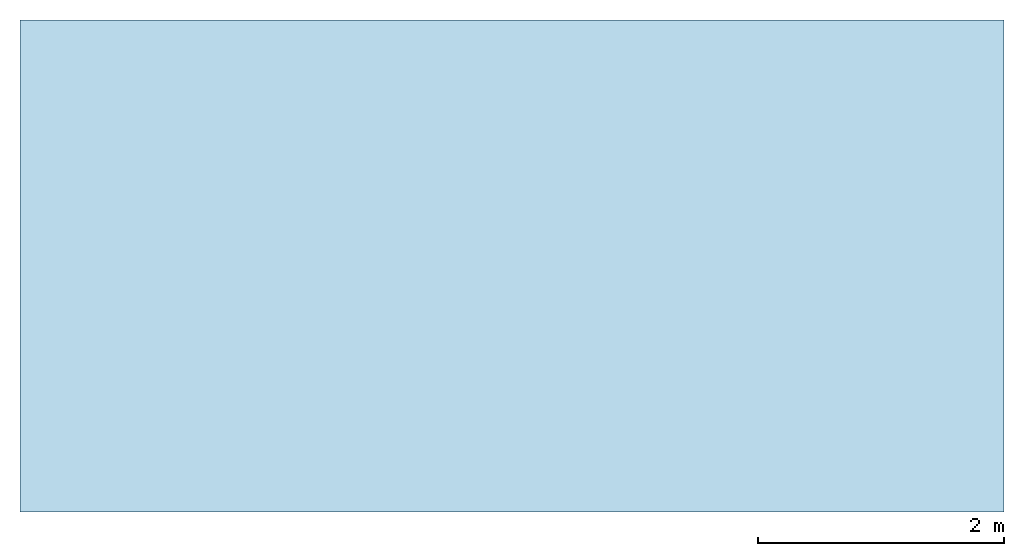
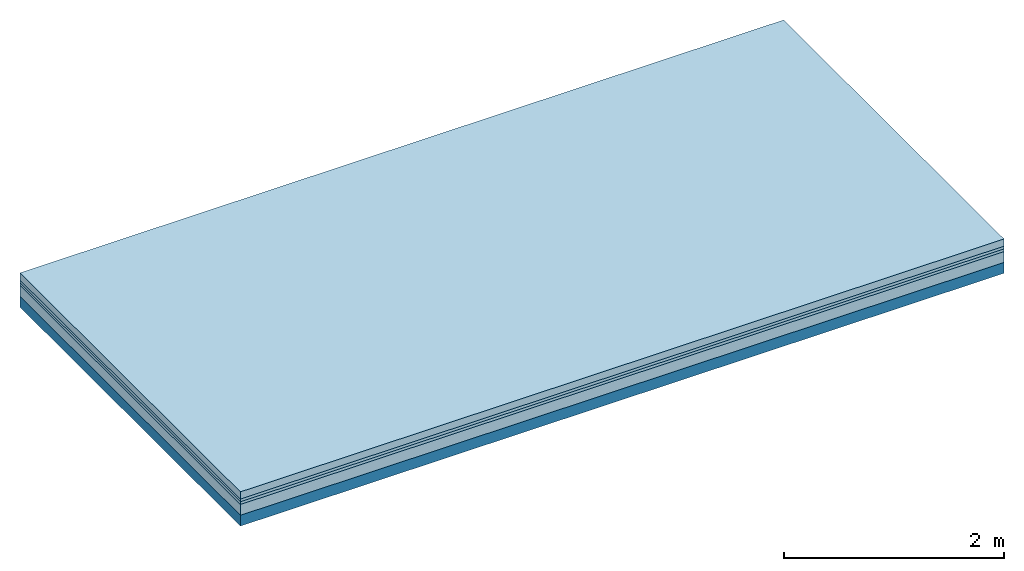
# One storey: 4 plates, 1 member, 1 element without a shape of its own.
"""IFC4 building model written with IfcOpenShell, lengths in metres."""

import ifcopenshell
import ifcopenshell.guid

model = None  # the IFC model being written
_history = None  # IfcOwnerHistory: only IFC2X3 demands one
_inside = {}  # id of a spatial element -> (the spatial element, [elements in it])
_under = {}  # id of a project, library or spatial element -> (it, [spatial elements below it])
_declared = {}  # id of a project -> (the project, [libraries it declares])
_typed = {}  # id of a type object -> (the type object, [elements of that type])
_made_of = {}  # id of a material, layer set ... -> (it, [elements and type objects made of it])


def new_model(schema):
    """Start an empty IFC model of exactly this schema.

    Asked for "IFC4X3", IfcOpenShell would pick the latest addendum, in which some entities
    have other attributes; the version numbers below select the first issue.
    IFC2X3 requires an IfcOwnerHistory on every rooted entity: one is made here for all.
    """
    global model, _history
    if schema == "IFC4X3":
        model = ifcopenshell.file(schema_version=(4, 3, 0, 0))
    else:
        model = ifcopenshell.file(schema=schema)
    _inside.clear()
    _under.clear()
    _declared.clear()
    _typed.clear()
    _made_of.clear()
    _history = None
    if model.schema == "IFC2X3":
        org = make("IfcOrganization", Name="unknown")
        user = make(
            "IfcPersonAndOrganization",
            ThePerson=make("IfcPerson", FamilyName="unknown"),
            TheOrganization=org,
        )
        app = make(
            "IfcApplication",
            ApplicationDeveloper=org,
            Version="unknown",
            ApplicationFullName="unknown",
            ApplicationIdentifier="unknown",
        )
        _history = make(
            "IfcOwnerHistory",
            OwningUser=user,
            OwningApplication=app,
            ChangeAction="ADDED",
            CreationDate=0,
        )
    return model


def make(cls, **values):
    """One entity of the class cls with the attributes given. An attribute that is None is left unset."""
    return model.create_entity(
        cls, **{name: value for name, value in values.items() if value is not None}
    )


def rooted(cls, **values):
    """An entity with a GlobalId (a new one), such as an element, a storey or a relation."""
    return make(cls, GlobalId=ifcopenshell.guid.new(), OwnerHistory=_history, **values)


def si_unit(unit_type, name, prefix=None):
    """IfcSIUnit, for example si_unit("LENGTHUNIT", "METRE", prefix="MILLI")."""
    return make("IfcSIUnit", UnitType=unit_type, Prefix=prefix, Name=name)


def derived_unit(unit_type, elements):
    """IfcDerivedUnit: a product of units, each with its exponent."""
    return make(
        "IfcDerivedUnit",
        Elements=[
            make("IfcDerivedUnitElement", Unit=unit, Exponent=power)
            for unit, power in elements
        ],
        UnitType=unit_type,
    )


def assignment(units):
    """IfcUnitAssignment: the units of a project."""
    return None if units is None else make("IfcUnitAssignment", Units=units)


def point(xyz):
    """IfcCartesianPoint."""
    return None if xyz is None else make("IfcCartesianPoint", Coordinates=xyz)


def direction(xyz):
    """IfcDirection."""
    return None if xyz is None else make("IfcDirection", DirectionRatios=xyz)


def frame(location, z_axis=None, x_axis=None):
    """IfcAxis2Placement3D, a coordinate frame: its origin and axes. An axis left out is left unset."""
    return make(
        "IfcAxis2Placement3D",
        Location=point(location),
        Axis=direction(z_axis),
        RefDirection=direction(x_axis),
    )


def frame_2d(location, x_axis=None):
    """IfcAxis2Placement2D, a coordinate frame in the plane: its origin and x axis."""
    return make(
        "IfcAxis2Placement2D", Location=point(location), RefDirection=direction(x_axis)
    )


def origin():
    """The frame at (0, 0, 0) with its axes left unset."""
    return frame((0.0, 0.0, 0.0))


def origin_with_axes():
    """The frame at (0, 0, 0) with the z axis (0, 0, 1) and the x axis (1, 0, 0) written out."""
    return frame((0.0, 0.0, 0.0), z_axis=(0.0, 0.0, 1.0), x_axis=(1.0, 0.0, 0.0))


def place(relative_to, where):
    """IfcLocalPlacement: puts the frame where relative to a parent placement (None: the world)."""
    return make(
        "IfcLocalPlacement", PlacementRelTo=relative_to, RelativePlacement=where
    )


def context(
    kind, dimensions, precision=None, world=None, true_north=None, identifier=None
):
    """IfcGeometricRepresentationContext, for example the 3D "Model" context."""
    return make(
        "IfcGeometricRepresentationContext",
        ContextIdentifier=identifier,
        ContextType=kind,
        CoordinateSpaceDimension=dimensions,
        Precision=precision,
        WorldCoordinateSystem=world,
        TrueNorth=true_north,
    )


def project(units=None, contexts=None):
    """IfcProject with its units and contexts."""
    return rooted(
        "IfcProject",
        Name="project",
        RepresentationContexts=contexts,
        UnitsInContext=assignment(units),
    )


def spatial(cls, under=None, at=None, **own):
    """A site, building, storey or space (cls), placed at a placement, below another one or the project."""
    s = rooted(cls, ObjectPlacement=at, **own)
    if under is not None:
        _under.setdefault(under.id(), (under, []))[1].append(s)
    return s


def profile(cls, at=None, kind="AREA", **sizes):
    """A parametric profile (cls). Its sizes go by their IFC names, for example OverallWidth=200.0."""
    return make(cls, ProfileType=kind, Position=at, **sizes)


def rectangle(**sizes):
    """IfcRectangleProfileDef."""
    return profile("IfcRectangleProfileDef", **sizes)


def extrude(swept, where, along, depth):
    """IfcExtrudedAreaSolid: the profile swept, set in the frame where, extruded along a direction by depth."""
    return make(
        "IfcExtrudedAreaSolid",
        SweptArea=swept,
        Position=where,
        ExtrudedDirection=direction(along),
        Depth=depth,
    )


def shape(context_of_items, identifier, shape_type, items):
    """IfcShapeRepresentation: the items that make up one representation, for example the "Body"."""
    return make(
        "IfcShapeRepresentation",
        ContextOfItems=context_of_items,
        RepresentationIdentifier=identifier,
        RepresentationType=shape_type,
        Items=items,
    )


def material(Name=None, Category=None):
    """IfcMaterial."""
    return make("IfcMaterial", Name=Name, Category=Category)


def layer(
    of_material, thickness, ventilated=None, Name=None, Category=None, Priority=None
):
    """IfcMaterialLayer: one layer of a wall or slab, of a material (None: an air gap)."""
    return make(
        "IfcMaterialLayer",
        Material=of_material,
        LayerThickness=thickness,
        IsVentilated=ventilated,
        Name=Name,
        Category=Category,
        Priority=Priority,
    )


def layer_set(layers, Name=None):
    """IfcMaterialLayerSet."""
    return make("IfcMaterialLayerSet", MaterialLayers=layers, LayerSetName=Name)


def made_of(thing, what):
    """Note that an element or type object is made of a material, layer set ...; save() writes the relation."""
    if what is not None:
        _made_of.setdefault(what.id(), (what, []))[1].append(thing)
    return thing


def type_object(cls, material=None, **own):
    """A type object (cls), such as IfcWallType, which elements share."""
    return made_of(rooted(cls, **own), material)


def element(
    cls,
    number,
    at=None,
    inside=None,
    cuts=None,
    type_object=None,
    material=None,
    context=None,
    identifier="Body",
    shape_type=None,
    held_by="IfcProductDefinitionShape",
    body=None,
    shapes=None,
    **own,
):
    """One element of the class cls, such as IfcWall. Its Tag is "e" and its number.

    at: its placement. inside: the storey or other place that contains it. cuts: it is an
    opening in that element (IfcRelVoidsElement). A single representation is given by context,
    identifier, shape_type and body (its items); several are given by shapes. held_by: the class
    of the entity that holds the representations. save() writes the other relations.
    """
    e = rooted(cls, Tag="e%d" % number, ObjectPlacement=at, **own)
    if body is not None:
        shapes = [shape(context, identifier, shape_type, body)]
    if shapes is not None:
        e.Representation = make(held_by, Representations=shapes)
    if inside is not None:
        _inside.setdefault(inside.id(), (inside, []))[1].append(e)
    if cuts is not None:
        rooted(
            "IfcRelVoidsElement", RelatingBuildingElement=cuts, RelatedOpeningElement=e
        )
    if type_object is not None:
        _typed.setdefault(type_object.id(), (type_object, []))[1].append(e)
    return made_of(e, material)


def aggregate(whole, parts):
    """IfcRelAggregates: a whole, such as a stair, and the parts it consists of."""
    return rooted("IfcRelAggregates", RelatingObject=whole, RelatedObjects=parts)


def save(model, path):
    """Write the relations noted so far, then the file.

    IfcRelAggregates (storeys below a building ...), IfcRelContainedInSpatialStructure (elements
    in a storey), IfcRelDefinesByType, IfcRelAssociatesMaterial and IfcRelDeclares: one each for
    every whole, place, type object, material and project.
    """
    for whole, parts in _under.values():
        aggregate(whole, parts)
    for where, things in _inside.values():
        rooted(
            "IfcRelContainedInSpatialStructure",
            RelatedElements=things,
            RelatingStructure=where,
        )
    for kind, things in _typed.values():
        rooted("IfcRelDefinesByType", RelatedObjects=things, RelatingType=kind)
    for what, things in _made_of.values():
        rooted("IfcRelAssociatesMaterial", RelatedObjects=things, RelatingMaterial=what)
    for by, libraries in _declared.values():
        rooted("IfcRelDeclares", RelatingContext=by, RelatedDefinitions=libraries)
    model.write(path)


model = new_model("IFC4")

# Units and contexts
plan_context = context("Plan", 3, precision=1e-05, world=origin(), true_north=direction((0.0, 1.0)))
model_context = context("Model", 3, precision=1e-05, world=origin(), true_north=direction((0.0, 1.0)))
ifc_project = project(units=[si_unit("LENGTHUNIT", "METRE"), derived_unit("SOUNDPRESSUREUNIT", [(si_unit("PRESSUREUNIT", "PASCAL", prefix="MICRO"), 0)]), si_unit("ENERGYUNIT", "JOULE", prefix="MEGA"), si_unit("MASSUNIT", "GRAM", prefix="KILO"), derived_unit("THERMALTRANSMITTANCEUNIT", [(si_unit("POWERUNIT", "WATT"), 1), (si_unit("AREAUNIT", "SQUARE_METRE"), -1), (si_unit("THERMODYNAMICTEMPERATUREUNIT", "KELVIN"), -1)]), derived_unit("AREADENSITYUNIT", [(si_unit("MASSUNIT", "GRAM", prefix="KILO"), 1), (si_unit("AREAUNIT", "SQUARE_METRE"), -1)]), derived_unit("USERDEFINED", [(si_unit("ENERGYUNIT", "JOULE", prefix="MEGA"), 1), (si_unit("AREAUNIT", "SQUARE_METRE"), -1)])], contexts=[plan_context, model_context])

# Site, building, storey
site = spatial("IfcSite", under=ifc_project)
building_placement = place(None, origin())
building = spatial("IfcBuilding", under=site, at=building_placement)
storey_placement = place(building_placement, origin())
storey = spatial("IfcBuildingStorey", under=building, at=storey_placement)

# Slab, member, plates
ifc_material_1 = material(Name="Cement screed", Category="04.006")
ifc_layer_1 = layer(ifc_material_1, 0.08, Name="On-material")
ifc_material_2 = material()
ifc_layer_2 = layer(ifc_material_2, 0.03, Name="Impact sound insulation")
ifc_material_3 = material()
ifc_layer_3 = layer(ifc_material_3, 0.03, Name="Additional insulation")
ifc_material_4 = material(Category="01.042")
ifc_layer_4 = layer(ifc_material_4, 0.12, Name="on Supporting structure")
ifc_material_5 = material(Name="of the art")
ifc_layer_5 = layer(ifc_material_5, 0.0, Name="Bond")
ifc_layer_6 = layer(None, 0.12, Name="Supporting structure")
ifc_layer_set = layer_set([ifc_layer_1, ifc_layer_2, ifc_layer_3, ifc_layer_4, ifc_layer_5, ifc_layer_6])
slab_type = type_object("IfcSlabType", Name="A1347", PredefinedType="NOTDEFINED", material=ifc_layer_set)
slab_placement = place(None, frame((0.0, 0.0, 0.0), z_axis=(0.0, 0.0, -1.0), x_axis=(1.0, 0.0, 0.0)))
slab = element("IfcSlab", 1, at=slab_placement, inside=storey, type_object=slab_type, material=ifc_layer_set, Name="Slab #1")
ifc_material_6 = material()
member_placement = place(slab_placement, origin())
member = element("IfcMember", 2, at=member_placement, material=ifc_material_6, Name="Supporting structure", context=plan_context, shape_type="SweptSolid", body=[
    extrude(rectangle(XDim=1.0, YDim=0.12, at=frame_2d((0.5, 0.06), x_axis=(1.0, 0.0))), frame((0.0, 4.0, 0.26), z_axis=(0.0, -1.0, 0.0), x_axis=(1.0, 0.0, 0.0)), (0.0, 0.0, 1.0), 4.0),
    extrude(rectangle(XDim=1.0, YDim=0.12, at=frame_2d((0.5, 0.06), x_axis=(1.0, 0.0))), frame((1.0, 4.0, 0.26), z_axis=(0.0, -1.0, 0.0), x_axis=(1.0, 0.0, 0.0)), (0.0, 0.0, 1.0), 4.0),
    extrude(rectangle(XDim=1.0, YDim=0.12, at=frame_2d((0.5, 0.06), x_axis=(1.0, 0.0))), frame((2.0, 4.0, 0.26), z_axis=(0.0, -1.0, 0.0), x_axis=(1.0, 0.0, 0.0)), (0.0, 0.0, 1.0), 4.0),
    extrude(rectangle(XDim=1.0, YDim=0.12, at=frame_2d((0.5, 0.06), x_axis=(1.0, 0.0))), frame((3.0, 4.0, 0.26), z_axis=(0.0, -1.0, 0.0), x_axis=(1.0, 0.0, 0.0)), (0.0, 0.0, 1.0), 4.0),
    extrude(rectangle(XDim=1.0, YDim=0.12, at=frame_2d((0.5, 0.06), x_axis=(1.0, 0.0))), frame((4.0, 4.0, 0.26), z_axis=(0.0, -1.0, 0.0), x_axis=(1.0, 0.0, 0.0)), (0.0, 0.0, 1.0), 4.0),
    extrude(rectangle(XDim=1.0, YDim=0.12, at=frame_2d((0.5, 0.06), x_axis=(1.0, 0.0))), frame((5.0, 4.0, 0.26), z_axis=(0.0, -1.0, 0.0), x_axis=(1.0, 0.0, 0.0)), (0.0, 0.0, 1.0), 4.0),
    extrude(rectangle(XDim=1.0, YDim=0.12, at=frame_2d((0.5, 0.06), x_axis=(1.0, 0.0))), frame((6.0, 4.0, 0.26), z_axis=(0.0, -1.0, 0.0), x_axis=(1.0, 0.0, 0.0)), (0.0, 0.0, 1.0), 4.0),
    extrude(rectangle(XDim=1.0, YDim=0.12, at=frame_2d((0.5, 0.06), x_axis=(1.0, 0.0))), frame((7.0, 4.0, 0.26), z_axis=(0.0, -1.0, 0.0), x_axis=(1.0, 0.0, 0.0)), (0.0, 0.0, 1.0), 4.0),
])
plate_1_placement = place(slab_placement, origin())
plate_1 = element("IfcPlate", 3, at=plate_1_placement, material=ifc_material_1, Name="On-material", context=plan_context, shape_type="SweptSolid", body=[
    extrude(rectangle(XDim=8.0, YDim=4.0, at=frame_2d((4.0, 2.0), x_axis=(1.0, 0.0))), origin_with_axes(), (0.0, 0.0, 1.0), 0.08),
])
plate_2_placement = place(slab_placement, origin())
plate_2 = element("IfcPlate", 4, at=plate_2_placement, material=ifc_material_2, Name="Impact sound insulation", context=plan_context, shape_type="SweptSolid", body=[
    extrude(rectangle(XDim=8.0, YDim=4.0, at=frame_2d((4.0, 2.0), x_axis=(1.0, 0.0))), frame((0.0, 0.0, 0.08), z_axis=(0.0, 0.0, 1.0), x_axis=(1.0, 0.0, 0.0)), (0.0, 0.0, 1.0), 0.03),
])
plate_3_placement = place(slab_placement, origin())
plate_3 = element("IfcPlate", 5, at=plate_3_placement, material=ifc_material_3, Name="Additional insulation", context=plan_context, shape_type="SweptSolid", body=[
    extrude(rectangle(XDim=8.0, YDim=4.0, at=frame_2d((4.0, 2.0), x_axis=(1.0, 0.0))), frame((0.0, 0.0, 0.11), z_axis=(0.0, 0.0, 1.0), x_axis=(1.0, 0.0, 0.0)), (0.0, 0.0, 1.0), 0.03),
])
plate_4_placement = place(slab_placement, origin())
plate_4 = element("IfcPlate", 6, at=plate_4_placement, material=ifc_material_4, Name="on Supporting structure", context=plan_context, shape_type="SweptSolid", body=[
    extrude(rectangle(XDim=8.0, YDim=4.0, at=frame_2d((4.0, 2.0), x_axis=(1.0, 0.0))), frame((0.0, 0.0, 0.14), z_axis=(0.0, 0.0, 1.0), x_axis=(1.0, 0.0, 0.0)), (0.0, 0.0, 1.0), 0.12),
])
aggregate(slab, [plate_1, plate_2, plate_3, plate_4, member])

save(model, "model.ifc")
